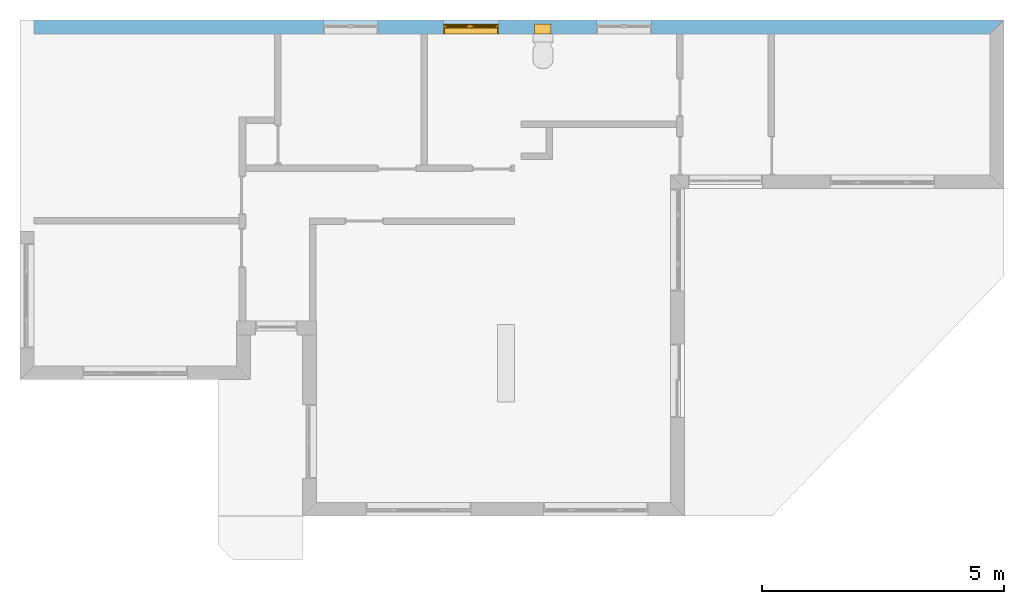
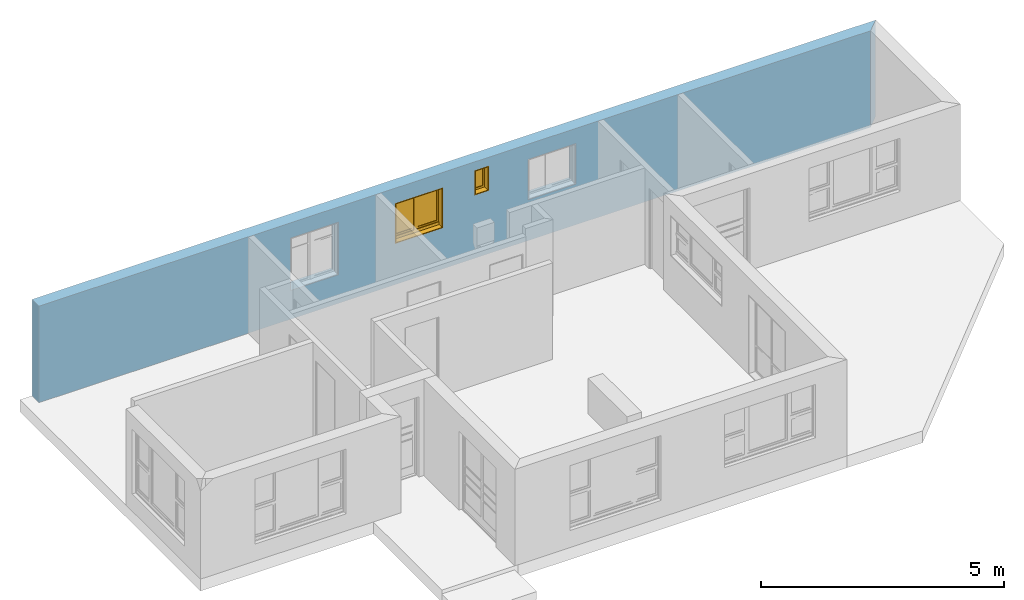
# One storey, part 13 of 15: 2 windows, 4 openings, plus 1 element that does not belong to this part.
"""IFC4 building model written with IfcOpenShell, lengths in millimetres."""

from ifc_helpers import new_model, entity, si_unit, converted_unit, frame, origin_with_axes, origin_2d_with_axis, place, context, subcontext, project, spatial, line, indexed_curve, outline, extrude, clip, halfspace, polygons, source, transform, mapped, material, layer, layer_set, layer_usage, type_object, type_shapes, element, fill, save


model = new_model("IFC4")

# Units and contexts
model_context = context("Model", 3, precision=1e-05, world=origin_with_axes())
plan_context = context("Plan", 2, precision=1e-05, world=origin_2d_with_axis())
body_context = subcontext(model_context, "Body", "Model", "MODEL_VIEW")
ifc_project = project(units=[si_unit("VOLUMEUNIT", "CUBIC_METRE"), si_unit("LENGTHUNIT", "METRE", prefix="MILLI"), converted_unit("PLANEANGLEUNIT", "degree", entity("IfcReal", 0.0174532925199433), si_unit("PLANEANGLEUNIT", "RADIAN"), dimensions=[0, 0, 0, 0, 0, 0, 0]), si_unit("AREAUNIT", "SQUARE_METRE")], contexts=[model_context, plan_context])

# Site, building, storey
site_placement = place(None, origin_with_axes())
site = spatial("IfcSite", under=ifc_project, at=site_placement)
building_placement = place(site_placement, origin_with_axes())
building = spatial("IfcBuilding", under=site, at=building_placement, Name="Building")
storey_placement = place(building_placement, origin_with_axes())
storey = spatial("IfcBuildingStorey", under=building, at=storey_placement, Name="EXISTING")

# Wall, openings, windows
ifc_material = material()
ifc_layer = layer(ifc_material, 285.0, Name="brick")
ifc_layer_set = layer_set([ifc_layer])
ifc_layer_usage = layer_usage(ifc_layer_set, "AXIS2", "POSITIVE", 0.0)
wall_type = type_object("IfcWallType", Name="285mm Wall", PredefinedType="STANDARD", material=ifc_layer_set)
wall_placement = place(storey_placement, frame((34.1207385063171, 5461.66706085205, 0.0), z_axis=(0.0, 0.0, 1.0), x_axis=(0.999999999999993, 1.19209282445353e-07, 0.0)))
wall = element("IfcWall", 1, at=wall_placement, inside=storey, type_object=wall_type, material=ifc_layer_usage, Name="Wall", context=body_context, shape_type="Clipping", body=[
    clip(extrude(outline(indexed_curve([(0.0, 0.0), (0.0, 285.0), (20070.0015485353, 285.0), (20070.0015485353, 0.0), (0.0, 0.0)], self_intersect=False)), origin_with_axes(), (0.0, 0.0, 1.0), 2425.00019073486), halfspace(frame((19785.0017547607, 2.1562527763308e-05, 0.0), z_axis=(0.707106709480286, -0.707106828689575, 0.0), x_axis=(-0.707106840791191, -0.707106721581899, 0.0)), False)),
])
shared_shape_1 = source(origin_with_axes(), body_context, "Body", "SweptSolid", [
    extrude(outline(indexed_curve([(0.0, 0.0), (340.000091552734, 0.0), (340.000091552734, 625.0), (0.0, 625.0)], segments=[line(1, 2, 3, 4, 1)])), frame((1.19209282445354e-07, -600.0, 0.0), z_axis=(0.0, -1.0, 0.0), x_axis=(1.0, 0.0, 0.0)), (0.0, 0.0, -1.0), 1200.0),
])
opening_1_placement = place(wall_placement, frame((10361.9993493649, 138.076500654373, 1585.00003814697), z_axis=(0.0, 0.0, 1.0), x_axis=(1.0, 0.0, 0.0)))
opening_1 = element("IfcOpeningElement", 2, at=opening_1_placement, cuts=wall, PredefinedType="OPENING", context=body_context, shape_type="MappedRepresentation", body=[
    mapped(shared_shape_1, transform((0.0, 0.0, 0.0), x_axis=(1.0, 0.0, 0.0), y_axis=(0.0, 1.0, 0.0), z_axis=(0.0, 0.0, 1.0), scale=1.0)),
])
shared_shape_2 = source(origin_with_axes(), body_context, "Body", "SweptSolid", [
    extrude(outline(indexed_curve([(0.0, 0.0), (1135.00012207031, 0.0), (1135.00012207031, 1014.99981689453), (0.0, 1014.99981689453)], segments=[line(1, 2, 3, 4, 1)])), frame((1.19209282445354e-07, -600.0, 0.0), z_axis=(0.0, -1.0, 0.0), x_axis=(1.0, 0.0, 0.0)), (0.0, 0.0, -1.0), 1200.0),
])
opening_2_placement = place(wall_placement, frame((8475.00021959052, 142.058315873181, 1030.00020980835), z_axis=(0.0, 0.0, 1.0), x_axis=(1.0, 0.0, 0.0)))
opening_2 = element("IfcOpeningElement", 3, at=opening_2_placement, cuts=wall, PredefinedType="OPENING", context=body_context, shape_type="MappedRepresentation", body=[
    mapped(shared_shape_2, transform((0.0, 0.0, 0.0), x_axis=(1.0, 0.0, 0.0), y_axis=(0.0, 1.0, 0.0), z_axis=(0.0, 0.0, 1.0), scale=1.0)),
])
shared_shape_3 = source(origin_with_axes(), body_context, "Body", "SweptSolid", [
    extrude(outline(indexed_curve([(0.0, 0.0), (1135.0, 0.0), (1135.0, 1321.99987792969), (0.0, 1321.99987792969)], segments=[line(1, 2, 3, 4, 1)])), frame((0.0, -600.0, -1.02445474325918e-08), z_axis=(0.0, -1.0, 0.0), x_axis=(1.0, 0.0, 0.0)), (0.0, 0.0, -1.0), 1200.0),
])
opening_3_placement = place(wall_placement, frame((5989.99865055079, 99.9991905691289, 723.000049591064), z_axis=(0.0, 0.0, 1.0), x_axis=(1.0, 0.0, 0.0)))
element("IfcOpeningElement", 4, at=opening_3_placement, cuts=wall, PredefinedType="OPENING", context=body_context, shape_type="MappedRepresentation", body=[
    mapped(shared_shape_3, transform((0.0, 0.0, 0.0), x_axis=(1.0, 0.0, 0.0), y_axis=(0.0, 1.0, 0.0), z_axis=(0.0, 0.0, 1.0), scale=1.0)),
])
shared_shape_4 = source(origin_with_axes(), body_context, "Body", "SweptSolid", [
    extrude(outline(indexed_curve([(0.0, 0.0), (1135.00024414062, 0.0), (1135.00024414062, 1019.99993896484), (0.0, 1019.99993896484)], segments=[line(1, 2, 3, 4, 1)])), frame((0.0, -600.0, -9.31322485797637e-09), z_axis=(0.0, -1.0, 0.0), x_axis=(1.0, 0.0, 0.0)), (0.0, 0.0, -1.0), 1200.0),
])
opening_4_placement = place(wall_placement, frame((11639.9992275636, 140.332741737542, 1025.00009536743), z_axis=(0.0, 0.0, 1.0), x_axis=(1.0, 0.0, 0.0)))
element("IfcOpeningElement", 5, at=opening_4_placement, cuts=wall, PredefinedType="OPENING", context=body_context, shape_type="MappedRepresentation", body=[
    mapped(shared_shape_4, transform((0.0, 0.0, 0.0), x_axis=(1.0, 0.0, 0.0), y_axis=(0.0, 1.0, 0.0), z_axis=(0.0, 0.0, 1.0), scale=1.0)),
])
window_type_1 = type_object("IfcWindowType", Name="Ex.1135x1015", PartitioningType="NOTDEFINED", PredefinedType="WINDOW")
shared_shape_5 = source(origin_with_axes(), body_context, "Body", "Tessellation", [
    polygons([(1135.00036621094, -142.058715820312, 0.0), (1135.00036621094, -142.058715820312, 19.999979019165), (0.00202655768953264, -142.058837890625, 0.0), (0.00202655768953264, -142.058837890625, 19.999979019165), (1135.00036621094, 57.9412574768066, 0.0), (1135.00036621094, 57.9412574768066, 19.999979019165), (0.00202655768953264, 57.9411697387695, 0.0), (0.00202655768953264, 57.9411697387695, 19.999979019165), (1134.99853515625, -142.058715820312, 994.999694824219), (1134.99853515625, -142.058715820312, 1014.99981689453), (0.000119209282274824, -142.058837890625, 994.999694824219), (0.000119209282274824, -142.058837890625, 1014.99981689453), (1134.99853515625, 57.9412574768066, 994.999694824219), (1134.99853515625, 57.9412574768066, 1014.99981689453), (0.000119209282274824, 57.9411697387695, 994.999694824219), (0.000119209282274824, 57.9411697387695, 1014.99981689453), (0.000119209282274824, -142.058715820312, 20.0000991821289), (19.9986686706543, -142.058715820312, 20.0000991821289), (0.000119209282274824, -142.058837890625, 994.999694824219), (19.9986686706543, -142.058837890625, 994.999694824219), (0.000119209282274824, 57.9412574768066, 20.0000991821289), (19.9986686706543, 57.9412574768066, 20.0000991821289), (0.000119209282274824, 57.9411392211914, 994.999694824219), (19.9986686706543, 57.9411697387695, 994.999694824219), (1114.99609375, -142.058715820312, 20.0000991821289), (1134.99853515625, -142.058715820312, 20.0000991821289), (1114.99609375, -142.058837890625, 994.999694824219), (1134.99853515625, -142.058837890625, 994.999694824219), (1114.99609375, 57.9412574768066, 20.0000991821289), (1134.99853515625, 57.9412574768066, 20.0000991821289), (1114.99609375, 57.9411697387695, 994.999694824219), (1134.99853515625, 57.9411697387695, 994.999694824219), (512.502807617188, -22.0587501525879, 20.0000991821289), (582.502502441406, -22.0587196350098, 20.0000991821289), (512.500915527344, -22.058780670166, 994.999816894531), (582.500610351562, -22.058780670166, 994.999816894531), (512.502807617188, 47.9412078857422, 20.0000991821289), (582.502502441406, 47.9412384033203, 20.0000991821289), (512.500915527344, 47.9412078857422, 994.999816894531), (582.500610351562, 47.9412078857422, 994.999816894531), (19.9967613220215, -7.05885457992554, 994.999694824219), (19.9967613220215, -7.05882501602173, 955.0), (512.4990234375, -7.05876541137695, 995.000305175781), (512.4990234375, -7.05873537063599, 955.000610351562), (19.9967613220215, 32.9411659240723, 994.999694824219), (19.9967613220215, 32.9411659240723, 955.000122070312), (512.4990234375, 32.9412231445312, 995.000305175781), (512.4990234375, 32.9412231445312, 955.000610351562), (19.9967613220215, -22.0588397979736, 89.9991912841797), (19.9967613220215, -22.0588092803955, 19.9998016357422), (512.4990234375, -22.0587501525879, 90.0000305175781), (512.4990234375, -22.0587196350098, 20.0005760192871), (19.9967613220215, 47.9411506652832, 89.9991912841797), (19.9967613220215, 47.9411506652832, 19.9998016357422), (512.4990234375, 47.9412078857422, 90.0000305175781), (512.4990234375, 47.9412689208984, 20.0005760192871), (582.498718261719, -22.0588397979736, 89.9991912841797), (582.498718261719, -22.0588092803955, 19.9998016357422), (1114.99609375, -22.0587501525879, 90.0000305175781), (1114.99609375, -22.0587196350098, 20.0005760192871), (582.498718261719, 47.9411506652832, 89.9991912841797), (582.498718261719, 47.9411506652832, 19.9998016357422), (1114.99609375, 47.9412078857422, 90.0000305175781), (1114.99609375, 47.9412689208984, 20.0005760192871), (19.9967613220215, -7.05885457992554, 129.998611450195), (19.9967613220215, -7.05882501602173, 89.9989547729492), (512.4990234375, -7.05876541137695, 129.999145507812), (512.4990234375, -7.05873537063599, 89.9994888305664), (19.9967613220215, 32.9411659240723, 129.998672485352), (19.9967613220215, 32.9411659240723, 89.9989547729492), (512.4990234375, 32.9412231445312, 129.999145507812), (512.4990234375, 32.9412231445312, 89.9994888305664), (59.9995803833008, -7.05876541137695, 955.00048828125), (20.0005760192871, -7.05876541137695, 955.00048828125), (59.9995803833008, -7.05876541137695, 129.999099731445), (20.0005760192871, -7.05873537063599, 129.999145507812), (59.9995803833008, 32.9412231445312, 955.00048828125), (20.0005760192871, 32.9412231445312, 955.00048828125), (59.9995803833008, 32.9412231445312, 129.999099731445), (20.0005760192871, 32.9412231445312, 129.999145507812), (512.500915527344, -7.05876541137695, 955.00048828125), (472.501892089844, -7.05876541137695, 955.00048828125), (512.500915527344, -7.05876541137695, 129.999145507812), (472.501892089844, -7.05873537063599, 129.999145507812), (512.500915527344, 32.9412231445312, 955.00048828125), (472.501892089844, 32.9412231445312, 955.00048828125), (512.500915527344, 32.9412231445312, 129.999145507812), (472.501892089844, 32.9412231445312, 129.999145507812), (582.498718261719, -7.05885457992554, 994.999694824219), (582.498718261719, -7.05882501602173, 955.0), (1114.99609375, -7.05876541137695, 995.000305175781), (1114.99609375, -7.05873537063599, 955.000610351562), (582.498718261719, 32.9411659240723, 994.999694824219), (582.498718261719, 32.9411659240723, 955.000122070312), (1114.99609375, 32.9412231445312, 995.000305175781), (1114.99609375, 32.9412231445312, 955.000610351562), (582.498718261719, -7.05885457992554, 129.998916625977), (582.498718261719, -7.05882501602173, 89.9992523193359), (1114.99609375, -7.05876541137695, 129.999450683594), (1114.99609375, -7.05873537063599, 89.9997863769531), (582.498718261719, 32.9411659240723, 129.998916625977), (582.498718261719, 32.9411659240723, 89.9992523193359), (1114.99609375, 32.9412231445312, 129.99951171875), (1114.99609375, 32.9412231445312, 89.9997863769531), (622.501525878906, -7.05876541137695, 955.000244140625), (582.502502441406, -7.05876541137695, 955.000244140625), (622.501525878906, -7.05876541137695, 129.999755859375), (582.502502441406, -7.05873537063599, 129.999755859375), (622.501525878906, 32.9412231445312, 955.000244140625), (582.502502441406, 32.9412231445312, 955.000244140625), (622.501525878906, 32.9412231445312, 129.999755859375), (582.502502441406, 32.9412231445312, 129.999755859375), (1114.99609375, -7.05876541137695, 955.000244140625), (1074.9970703125, -7.05876541137695, 955.000244140625), (1114.99609375, -7.05876541137695, 129.999633789062), (1074.9970703125, -7.05873537063599, 129.999633789062), (1114.99609375, 32.9412231445312, 955.000244140625), (1074.9970703125, 32.9412231445312, 955.000244140625), (1114.99609375, 32.9412231445312, 129.999633789062), (1074.9970703125, 32.9412231445312, 129.999633789062), (1074.9970703125, 7.94121932983398, 955.000244140625), (622.50341796875, 7.94124937057495, 955.000244140625), (1074.9970703125, 7.94121932983398, 129.999633789062), (622.50341796875, 7.94124937057495, 129.999755859375), (1074.9970703125, 17.9412384033203, 955.000244140625), (622.50341796875, 17.9412384033203, 955.000244140625), (1074.9970703125, 17.9412384033203, 129.999633789062), (622.50341796875, 17.9412384033203, 129.999755859375), (472.5, 7.94121932983398, 955.000366210938), (59.9995803833008, 7.94124937057495, 955.00048828125), (472.498077392578, 7.94121932983398, 130.000579833984), (59.997673034668, 7.94124937057495, 130.000579833984), (472.5, 17.9412384033203, 955.000366210938), (59.9995803833008, 17.9412384033203, 955.00048828125), (472.498077392578, 17.9412384033203, 130.000579833984), (59.997673034668, 17.9412384033203, 130.000579833984)], [[[1, 2, 4, 3]], [[3, 4, 8, 7]], [[7, 8, 6, 5]], [[5, 6, 2, 1]], [[3, 7, 5, 1]], [[8, 4, 2, 6]], [[9, 10, 12, 11]], [[11, 12, 16, 15]], [[15, 16, 14, 13]], [[13, 14, 10, 9]], [[11, 15, 13, 9]], [[16, 12, 10, 14]], [[17, 18, 20, 19]], [[19, 20, 24, 23]], [[23, 24, 22, 21]], [[21, 22, 18, 17]], [[19, 23, 21, 17]], [[24, 20, 18, 22]], [[25, 26, 28, 27]], [[27, 28, 32, 31]], [[31, 32, 30, 29]], [[29, 30, 26, 25]], [[27, 31, 29, 25]], [[32, 28, 26, 30]], [[33, 34, 36, 35]], [[35, 36, 40, 39]], [[39, 40, 38, 37]], [[37, 38, 34, 33]], [[35, 39, 37, 33]], [[40, 36, 34, 38]], [[41, 42, 44, 43]], [[43, 44, 48, 47]], [[47, 48, 46, 45]], [[45, 46, 42, 41]], [[43, 47, 45, 41]], [[48, 44, 42, 46]], [[49, 50, 52, 51]], [[51, 52, 56, 55]], [[55, 56, 54, 53]], [[53, 54, 50, 49]], [[51, 55, 53, 49]], [[56, 52, 50, 54]], [[57, 58, 60, 59]], [[59, 60, 64, 63]], [[63, 64, 62, 61]], [[61, 62, 58, 57]], [[59, 63, 61, 57]], [[64, 60, 58, 62]], [[65, 66, 68, 67]], [[67, 68, 72, 71]], [[71, 72, 70, 69]], [[69, 70, 66, 65]], [[67, 71, 69, 65]], [[72, 68, 66, 70]], [[73, 74, 76, 75]], [[75, 76, 80, 79]], [[79, 80, 78, 77]], [[77, 78, 74, 73]], [[75, 79, 77, 73]], [[80, 76, 74, 78]], [[81, 82, 84, 83]], [[83, 84, 88, 87]], [[87, 88, 86, 85]], [[85, 86, 82, 81]], [[83, 87, 85, 81]], [[88, 84, 82, 86]], [[89, 90, 92, 91]], [[91, 92, 96, 95]], [[95, 96, 94, 93]], [[93, 94, 90, 89]], [[91, 95, 93, 89]], [[96, 92, 90, 94]], [[97, 98, 100, 99]], [[99, 100, 104, 103]], [[103, 104, 102, 101]], [[101, 102, 98, 97]], [[99, 103, 101, 97]], [[104, 100, 98, 102]], [[105, 106, 108, 107]], [[107, 108, 112, 111]], [[111, 112, 110, 109]], [[109, 110, 106, 105]], [[107, 111, 109, 105]], [[112, 108, 106, 110]], [[113, 114, 116, 115]], [[115, 116, 120, 119]], [[119, 120, 118, 117]], [[117, 118, 114, 113]], [[115, 119, 117, 113]], [[120, 116, 114, 118]], [[121, 122, 124, 123]], [[123, 124, 128, 127]], [[127, 128, 126, 125]], [[125, 126, 122, 121]], [[123, 127, 125, 121]], [[128, 124, 122, 126]], [[129, 130, 132, 131]], [[131, 132, 136, 135]], [[135, 136, 134, 133]], [[133, 134, 130, 129]], [[131, 135, 133, 129]], [[136, 132, 130, 134]]], closed=True),
])
type_shapes(window_type_1, [shared_shape_5])
window_1_placement = place(opening_2_placement, frame((0.0, 8.88178419700125e-13, -4.44089209850063e-13), z_axis=(0.0, 0.0, 1.0), x_axis=(1.0, 3.97046694025453e-23, 0.0)))
window_1 = element("IfcWindow", 6, at=window_1_placement, inside=storey, type_object=window_type_1, Name="Window", context=body_context, shape_type="MappedRepresentation", body=[
    mapped(shared_shape_5, transform((0.0, 0.0, 0.0), x_axis=(1.0, 0.0, 0.0), y_axis=(0.0, 1.0, 0.0), z_axis=(0.0, 0.0, 1.0), scale=1.0)),
])
fill(opening_2, window_1)
window_type_2 = type_object("IfcWindowType", Name="Ex.340x625", PartitioningType="NOTDEFINED", PredefinedType="WINDOW")
shared_shape_6 = source(origin_with_axes(), body_context, "Body", "Tessellation", [
    polygons([(340.000244140625, -138.076858520508, 0.0), (340.000244140625, -138.076858520508, 19.999979019165), (0.00202655768953264, -138.076919555664, 0.0), (0.00202655768953264, -138.076919555664, 19.999979019165), (340.000244140625, 61.9231452941895, 0.0), (340.000244140625, 61.9231452941895, 19.999979019165), (0.00202655768953264, 61.9230575561523, 0.0), (0.00202655768953264, 61.9230575561523, 19.999979019165), (339.998352050781, -138.076858520508, 605.000122070312), (339.998352050781, -138.076858520508, 625.000061035156), (0.000119209282274824, -138.076919555664, 605.000122070312), (0.000119209282274824, -138.076919555664, 625.000061035156), (339.998352050781, 61.9231452941895, 605.000122070312), (339.998352050781, 61.9231452941895, 625.000061035156), (0.000119209282274824, 61.9230575561523, 605.000122070312), (0.000119209282274824, 61.9230575561523, 625.000061035156), (0.000119209282274824, -138.076858520508, 20.0000400543213), (20.0005760192871, -138.076858520508, 20.0000400543213), (0.000119209282274824, -138.076919555664, 605.000122070312), (20.0005760192871, -138.076919555664, 605.000122070312), (0.000119209282274824, 61.9231147766113, 20.0000400543213), (20.0005760192871, 61.9231452941895, 20.0000400543213), (0.000119209282274824, 61.9230575561523, 605.000122070312), (20.0005760192871, 61.9230575561523, 605.000122070312), (20.0005760192871, -3.07696676254272, 604.99951171875), (20.0005760192871, -3.07693696022034, 564.999877929688), (319.999786376953, -3.07687735557556, 605.000122070312), (319.999786376953, -3.07687735557556, 565.000366210938), (20.0005760192871, 36.923023223877, 604.99951171875), (20.0005760192871, 36.9230537414551, 564.999877929688), (319.999786376953, 36.9231109619141, 605.000122070312), (319.999786376953, 36.9231414794922, 565.000366210938), (20.0005760192871, -3.07696676254272, 64.9997253417969), (20.0005760192871, -3.07693696022034, 19.9998893737793), (319.999786376953, -3.07687735557556, 65.0002593994141), (319.999786376953, -3.07687735557556, 20.0004272460938), (20.0005760192871, 36.923023223877, 64.999755859375), (20.0005760192871, 36.9230537414551, 19.9998893737793), (319.999786376953, 36.9231109619141, 65.0002593994141), (319.999786376953, 36.9231414794922, 20.0004272460938), (59.9995803833008, -3.07687735557556, 565.000244140625), (20.0024833679199, -3.07687735557556, 565.000244140625), (59.9995803833008, -3.07687735557556, 65.0001754760742), (20.0024833679199, -3.07687735557556, 65.0002059936523), (59.9995803833008, 36.9231109619141, 565.000244140625), (20.0024833679199, 36.9231109619141, 565.000244140625), (59.9995803833008, 36.9231414794922, 65.0001754760742), (20.0024833679199, 36.9231414794922, 65.0002059936523), (319.997894287109, -3.07687735557556, 565.000244140625), (280.000793457031, -3.07687735557556, 565.000244140625), (319.997894287109, -3.07687735557556, 65.0001754760742), (280.000793457031, -3.07687735557556, 65.0002059936523), (319.999786376953, 36.9231109619141, 565.000244140625), (280.000793457031, 36.9231109619141, 565.000244140625), (319.997894287109, 36.9231414794922, 65.0001754760742), (280.000793457031, 36.9231414794922, 65.0002059936523), (280.002685546875, 11.9231071472168, 565.000122070312), (59.9995803833008, 11.9231071472168, 565.000122070312), (280.002685546875, 11.9231071472168, 465.000274658203), (59.997673034668, 11.9231071472168, 465.000274658203), (280.002685546875, 21.9230976104736, 565.000122070312), (59.9995803833008, 21.9231281280518, 565.000122070312), (280.002685546875, 21.9231281280518, 465.000274658203), (59.997673034668, 21.9231281280518, 465.000274658203), (319.999786376953, -138.076858520508, 20.0000400543213), (340.000244140625, -138.076858520508, 20.0000400543213), (319.999786376953, -138.076919555664, 605.000122070312), (340.000244140625, -138.076919555664, 605.000122070312), (319.999786376953, 61.9231147766113, 20.0000400543213), (340.000244140625, 61.9231452941895, 20.0000400543213), (319.999786376953, 61.9230575561523, 605.000122070312), (340.000244140625, 61.9230575561523, 605.000122070312), (280.002685546875, 11.9231071472168, 465.000274658203), (59.9995803833008, 11.9231071472168, 465.000274658203), (280.002685546875, 11.9231071472168, 365.000244140625), (59.997673034668, 11.9231071472168, 365.000305175781), (280.002685546875, 21.9230976104736, 465.000274658203), (59.9995803833008, 21.9231281280518, 465.000274658203), (280.002685546875, 21.9231281280518, 365.000244140625), (59.997673034668, 21.9231281280518, 365.000305175781), (280.002685546875, 11.9231071472168, 365.000244140625), (59.9995803833008, 11.9231071472168, 365.000244140625), (280.002685546875, 11.9231071472168, 265.000305175781), (59.997673034668, 11.9231071472168, 265.000366210938), (280.002685546875, 21.9230976104736, 365.000244140625), (59.9995803833008, 21.9231281280518, 365.000244140625), (280.002685546875, 21.9231281280518, 265.000305175781), (59.997673034668, 21.9231281280518, 265.000366210938), (280.002685546875, 11.9231071472168, 265.000305175781), (59.9995803833008, 11.9231071472168, 265.000305175781), (280.002685546875, 11.9231071472168, 165.000335693359), (59.997673034668, 11.9231071472168, 165.000366210938), (280.002685546875, 21.9230976104736, 265.000305175781), (59.9995803833008, 21.9231281280518, 265.000305175781), (280.002685546875, 21.9231281280518, 165.000335693359), (59.997673034668, 21.9231281280518, 165.000366210938), (280.002685546875, 11.9231071472168, 165.00016784668), (59.9995803833008, 11.9231071472168, 165.00016784668), (280.002685546875, 11.9231071472168, 65.0002059936523), (59.997673034668, 11.9231071472168, 65.0002288818359), (280.002685546875, 21.9230976104736, 165.00016784668), (59.9995803833008, 21.9231281280518, 165.00016784668), (280.002685546875, 21.9231281280518, 65.0002059936523), (59.997673034668, 21.9231281280518, 65.0002288818359)], [[[1, 2, 4, 3]], [[3, 4, 8, 7]], [[7, 8, 6, 5]], [[5, 6, 2, 1]], [[3, 7, 5, 1]], [[8, 4, 2, 6]], [[9, 10, 12, 11]], [[11, 12, 16, 15]], [[15, 16, 14, 13]], [[13, 14, 10, 9]], [[11, 15, 13, 9]], [[16, 12, 10, 14]], [[17, 18, 20, 19]], [[19, 20, 24, 23]], [[23, 24, 22, 21]], [[21, 22, 18, 17]], [[19, 23, 21, 17]], [[24, 20, 18, 22]], [[25, 26, 28, 27]], [[27, 28, 32, 31]], [[31, 32, 30, 29]], [[29, 30, 26, 25]], [[27, 31, 29, 25]], [[32, 28, 26, 30]], [[33, 34, 36, 35]], [[35, 36, 40, 39]], [[39, 40, 38, 37]], [[37, 38, 34, 33]], [[35, 39, 37, 33]], [[40, 36, 34, 38]], [[41, 42, 44, 43]], [[43, 44, 48, 47]], [[47, 48, 46, 45]], [[45, 46, 42, 41]], [[43, 47, 45, 41]], [[48, 44, 42, 46]], [[49, 50, 52, 51]], [[51, 52, 56, 55]], [[55, 56, 54, 53]], [[53, 54, 50, 49]], [[51, 55, 53, 49]], [[56, 52, 50, 54]], [[57, 58, 60, 59]], [[59, 60, 64, 63]], [[63, 64, 62, 61]], [[61, 62, 58, 57]], [[59, 63, 61, 57]], [[64, 60, 58, 62]], [[65, 66, 68, 67]], [[67, 68, 72, 71]], [[71, 72, 70, 69]], [[69, 70, 66, 65]], [[67, 71, 69, 65]], [[72, 68, 66, 70]], [[73, 74, 76, 75]], [[75, 76, 80, 79]], [[79, 80, 78, 77]], [[77, 78, 74, 73]], [[75, 79, 77, 73]], [[80, 76, 74, 78]], [[81, 82, 84, 83]], [[83, 84, 88, 87]], [[87, 88, 86, 85]], [[85, 86, 82, 81]], [[83, 87, 85, 81]], [[88, 84, 82, 86]], [[89, 90, 92, 91]], [[91, 92, 96, 95]], [[95, 96, 94, 93]], [[93, 94, 90, 89]], [[91, 95, 93, 89]], [[96, 92, 90, 94]], [[97, 98, 100, 99]], [[99, 100, 104, 103]], [[103, 104, 102, 101]], [[101, 102, 98, 97]], [[99, 103, 101, 97]], [[104, 100, 98, 102]]], closed=True),
])
type_shapes(window_type_2, [shared_shape_6])
window_2_placement = place(opening_1_placement, frame((-8.88178419700125e-12, 8.88178419700125e-13, 2.66453525910038e-12), z_axis=(0.0, 0.0, 1.0), x_axis=(1.0, 3.97046694025453e-23, 0.0)))
window_2 = element("IfcWindow", 7, at=window_2_placement, inside=storey, type_object=window_type_2, Name="Window", context=body_context, shape_type="MappedRepresentation", body=[
    mapped(shared_shape_6, transform((0.0, 0.0, 0.0), x_axis=(1.0, 0.0, 0.0), y_axis=(0.0, 1.0, 0.0), z_axis=(0.0, 0.0, 1.0), scale=1.0)),
])
fill(opening_1, window_2)

save(model, "model.ifc")
